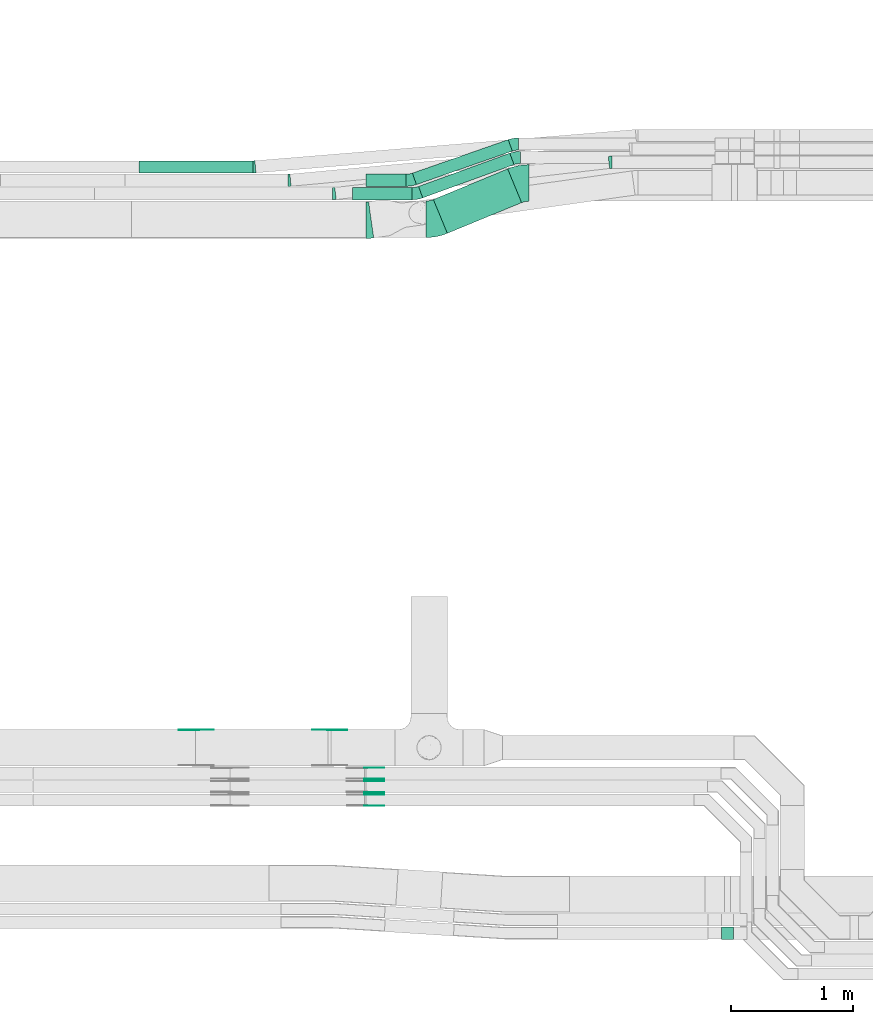
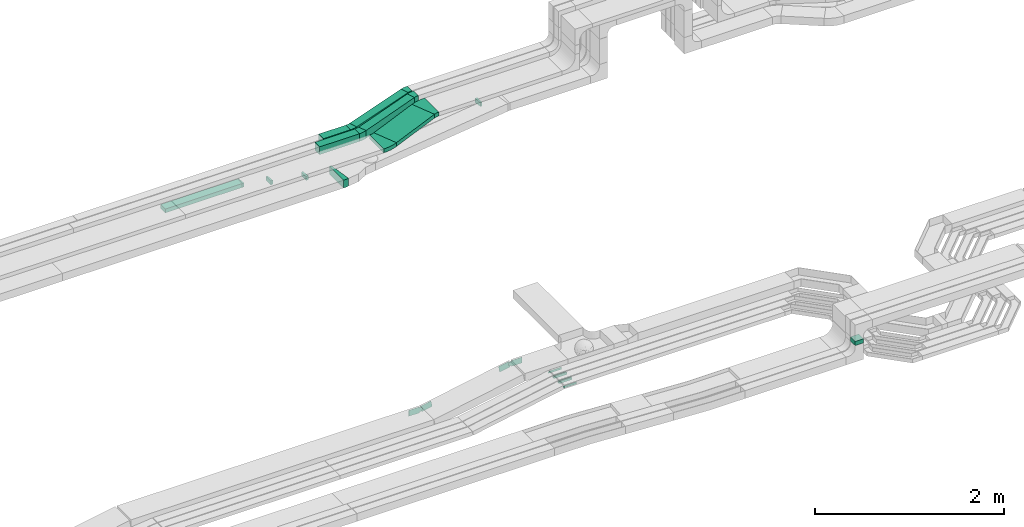
# One storey, part 13 of 33: 21 flow fittings, 7 flow segments.
"""IFC2X3 building model written with IfcOpenShell, lengths in millimetres."""

from ifc_helpers import new_model, entity, si_unit, converted_unit, derived_unit, direction, frame, frame_2d, origin, origin_2d_with_axis, place, context, subcontext, project, spatial, polyline, circle_curve, parameter, trimmed, segment, composite_curve, rectangle, outline, extrude, source, transform, mapped, material, type_object, type_shapes, element, save


model = new_model("IFC2X3")

# Units and contexts
model_context = context("Model", 3, precision=0.01, world=origin(), true_north=direction((6.12303176911189e-17, 1.0)))
body_context = subcontext(model_context, "Body", "Model", "MODEL_VIEW")
ifc_project = project(units=[si_unit("LENGTHUNIT", "METRE", prefix="MILLI"), si_unit("AREAUNIT", "SQUARE_METRE"), si_unit("VOLUMEUNIT", "CUBIC_METRE"), converted_unit("PLANEANGLEUNIT", "DEGREE", entity("IfcRatioMeasure", 0.0174532925199433), si_unit("PLANEANGLEUNIT", "RADIAN"), dimensions=[0, 0, 0, 0, 0, 0, 0]), si_unit("MASSUNIT", "GRAM", prefix="KILO"), derived_unit("MASSDENSITYUNIT", [(si_unit("MASSUNIT", "GRAM", prefix="KILO"), 1), (si_unit("LENGTHUNIT", "METRE"), -3)]), derived_unit("MOMENTOFINERTIAUNIT", [(si_unit("LENGTHUNIT", "METRE"), 4)]), si_unit("TIMEUNIT", "SECOND"), si_unit("FREQUENCYUNIT", "HERTZ"), si_unit("THERMODYNAMICTEMPERATUREUNIT", "DEGREE_CELSIUS"), derived_unit("THERMALTRANSMITTANCEUNIT", [(si_unit("MASSUNIT", "GRAM", prefix="KILO"), 1), (si_unit("THERMODYNAMICTEMPERATUREUNIT", "KELVIN"), -1), (si_unit("TIMEUNIT", "SECOND"), -3)]), derived_unit("VOLUMETRICFLOWRATEUNIT", [(si_unit("LENGTHUNIT", "METRE"), 3), (si_unit("TIMEUNIT", "SECOND"), -1)]), derived_unit("MASSFLOWRATEUNIT", [(si_unit("MASSUNIT", "GRAM", prefix="KILO"), 1), (si_unit("TIMEUNIT", "SECOND"), -1)]), derived_unit("ROTATIONALFREQUENCYUNIT", [(si_unit("TIMEUNIT", "SECOND"), -1)]), si_unit("ELECTRICCURRENTUNIT", "AMPERE"), si_unit("ELECTRICVOLTAGEUNIT", "VOLT"), si_unit("POWERUNIT", "WATT"), si_unit("FORCEUNIT", "NEWTON", prefix="KILO"), si_unit("ILLUMINANCEUNIT", "LUX"), si_unit("LUMINOUSFLUXUNIT", "LUMEN"), si_unit("LUMINOUSINTENSITYUNIT", "CANDELA"), derived_unit("USERDEFINED", [(si_unit("MASSUNIT", "GRAM", prefix="KILO"), -1), (si_unit("LENGTHUNIT", "METRE"), -2), (si_unit("TIMEUNIT", "SECOND"), 3), (si_unit("LUMINOUSFLUXUNIT", "LUMEN"), 1)]), derived_unit("LINEARVELOCITYUNIT", [(si_unit("LENGTHUNIT", "METRE"), 1), (si_unit("TIMEUNIT", "SECOND"), -1)]), si_unit("PRESSUREUNIT", "PASCAL"), derived_unit("USERDEFINED", [(si_unit("LENGTHUNIT", "METRE"), -2), (si_unit("MASSUNIT", "GRAM", prefix="KILO"), 1), (si_unit("TIMEUNIT", "SECOND"), -2)]), derived_unit("LINEARFORCEUNIT", [(si_unit("MASSUNIT", "GRAM", prefix="KILO"), 1), (si_unit("LENGTHUNIT", "METRE"), 1), (si_unit("TIMEUNIT", "SECOND"), -2), (si_unit("LENGTHUNIT", "METRE"), -1)]), derived_unit("PLANARFORCEUNIT", [(si_unit("MASSUNIT", "GRAM", prefix="KILO"), 1), (si_unit("LENGTHUNIT", "METRE"), 1), (si_unit("TIMEUNIT", "SECOND"), -2), (si_unit("LENGTHUNIT", "METRE"), -2)])], contexts=[model_context])

# Site, building, storey
site_placement = place(None, frame((0.0, -0.00077364408347762, 0.0)))
site = spatial("IfcSite", under=ifc_project, at=site_placement, CompositionType="ELEMENT")
building_placement = place(site_placement, origin())
building = spatial("IfcBuilding", under=site, at=building_placement, CompositionType="ELEMENT")
storey_placement = place(building_placement, frame((0.0, 0.0, 8100.0)))
storey = spatial("IfcBuildingStorey", under=building, at=storey_placement, CompositionType="ELEMENT", Elevation=8100.0)

# Flow segments
cable_carrier_segment_type = type_object("IfcCableCarrierSegmentType", PredefinedType="CABLETRAYSEGMENT")
flow_segment_1_placement = place(storey_placement, frame((27126.5045449638, 14216.6993529965, 2840.01712441882)))
element("IfcFlowSegment", 1, at=flow_segment_1_placement, inside=storey, type_object=cable_carrier_segment_type, context=body_context, shape_type="SweptSolid", body=[
    extrude(rectangle(XDim=659.52836889801, YDim=299.999999999997, at=frame_2d((8.24229573481716e-13, 2.01794136955868e-12), x_axis=(1.0, 0.0))), frame((362.049152556939, 264.468387444949, 0.0), z_axis=(0.0, 0.0, 1.0), x_axis=(-0.924356472691493, -0.381529961331139, 0.0)), (0.0, 0.0, 1.0), 50.0000000000016),
])
flow_segment_2_placement = place(storey_placement, frame((27004.8221282294, 14507.7317478892, 2840.0)))
element("IfcFlowSegment", 2, at=flow_segment_2_placement, inside=storey, type_object=cable_carrier_segment_type, context=body_context, shape_type="SweptSolid", body=[
    extrude(rectangle(XDim=797.077067377563, YDim=99.9999999999991, at=frame_2d((3.32534000335727e-12, -3.5278446830489e-12), x_axis=(1.0, 0.0))), frame((391.56891335788, 183.435992552252, 0.0), z_axis=(0.0, 0.0, 1.0), x_axis=(-0.939555537595458, -0.342396541708164, 0.0)), (0.0, 0.0, 1.0), 99.9999999999989),
])
flow_segment_3_placement = place(storey_placement, frame((26954.3095022686, 14616.5840674657, 2840.0)))
element("IfcFlowSegment", 3, at=flow_segment_3_placement, inside=storey, type_object=cable_carrier_segment_type, context=body_context, shape_type="SweptSolid", body=[
    extrude(rectangle(XDim=833.426581075166, YDim=100.000000000001, at=frame_2d((2.35900188272353e-12, 3.23296944770846e-13), x_axis=(1.0, 0.0))), frame((409.90070942409, 184.583672975688, 0.0), z_axis=(0.0, 0.0, 1.0), x_axis=(-0.944095363050818, -0.329672482118153, 0.0)), (0.0, 0.0, 1.0), 99.9999999999989),
])
flow_segment_4_placement = place(storey_placement, frame((24709.6133048514, 14712.2782357463, 2570.0)))
element("IfcFlowSegment", 4, at=flow_segment_4_placement, inside=storey, type_object=cable_carrier_segment_type, context=body_context, shape_type="SweptSolid", body=[
    extrude(rectangle(XDim=937.962058538578, YDim=99.9999999999989, at=frame_2d((0.0, 2.16715534406831e-12), x_axis=(1.0, 0.0))), frame((468.981029269289, 50.0, 0.0)), (0.0, 0.0, 1.0), 50.0000000000016),
])
flow_segment_5_placement = place(storey_placement, frame((26464.099792896, 14492.2782357463, 2840.0)))
element("IfcFlowSegment", 5, at=flow_segment_5_placement, inside=storey, type_object=cable_carrier_segment_type, context=body_context, shape_type="SweptSolid", body=[
    extrude(rectangle(XDim=487.423298539587, YDim=99.9999999999989, at=origin_2d_with_axis()), frame((243.711649269793, 50.0, 0.0)), (0.0, 0.0, 1.0), 99.9999999999989),
])
flow_segment_6_placement = place(storey_placement, frame((26574.099792896, 14602.2782357463, 2840.0)))
element("IfcFlowSegment", 6, at=flow_segment_6_placement, inside=storey, type_object=cable_carrier_segment_type, context=body_context, shape_type="SweptSolid", body=[
    extrude(rectangle(XDim=328.814741691739, YDim=99.9999999999989, at=origin_2d_with_axis()), frame((164.40737084587, 50.0, 0.0)), (0.0, 0.0, 1.0), 99.9999999999989),
])
flow_segment_7_placement = place(storey_placement, frame((29489.4603210585, 8422.4518205444, 2999.3193251973)))
element("IfcFlowSegment", 7, at=flow_segment_7_placement, inside=storey, type_object=cable_carrier_segment_type, context=body_context, shape_type="SweptSolid", body=[
    extrude(rectangle(XDim=100.000000000001, YDim=100.000000000003, at=frame_2d((1.08357767203415e-12, -4.33431068813661e-12), x_axis=(1.0, 0.0))), frame((50.0, 50.0, 0.0), z_axis=(0.0, 0.0, 1.0), x_axis=(0.0, 1.0, 0.0)), (0.0, 0.0, 1.0), 54.9788826680355),
])

# Flow fittings
ifc_material_1 = material()
cable_carrier_fitting_type_1 = type_object("IfcCableCarrierFittingType", Name="470_DKC_S5_Variable Angle Elbow 0-45:-", PredefinedType="NOTDEFINED", material=ifc_material_1)
shared_shape_1 = source(origin(), body_context, "Body", "SweptSolid", [
    extrude(outline(composite_curve([segment(polyline([(-12.2888732950033, -50.6676442286709), (-11.288873295002, -50.6676442286709)]), True, "CONTINUOUS"), segment(trimmed(circle_curve(frame_2d((-11.2888732950024, 199.332355771329), x_axis=(0.0, -1.0)), 250.0), [parameter(0.0)], [parameter(6.48278712085122)], True, "PARAMETER"), True, "CONTINUOUS"), segment(polyline([(16.9373063053102, -49.0690991059942), (17.9309121248195, -48.956194387593)]), True, "CONTINUOUS"), segment(polyline([(17.9309121248195, -48.956194387593), (6.64044028469449, 50.4043875633362)]), True, "CONTINUOUS"), segment(polyline([(6.64044028469449, 50.4043875633362), (5.64683446518516, 50.291482844935)]), True, "CONTINUOUS"), segment(trimmed(circle_curve(frame_2d((-11.2888732950024, 199.332355771329), x_axis=(0.0, -1.0)), 150.0), [parameter(0.0)], [parameter(6.48278712085122)], True, "PARAMETER"), False, "CONTINUOUS"), segment(polyline([(-11.288873295002, 49.3323557713289), (-12.2888732950033, 49.3323557713289)]), True, "CONTINUOUS"), segment(polyline([(-12.2888732950033, 49.3323557713289), (-12.2888732950033, -50.6676442286709)]), True, "CONTINUOUS")], self_intersect=False)), frame((-0.0378109769108159, 0.667644228662868, -25.0)), (0.0, 0.0, 1.0), 50.0000000000002),
])
type_shapes(cable_carrier_fitting_type_1, [shared_shape_1])
flow_fitting_1_placement = place(storey_placement, frame((28579.3619434365, 14800.0572451365, 2590.34290576127), z_axis=(0.0, 0.0, 1.0), x_axis=(-1.0, 0.0, 0.0)))
element("IfcFlowFitting", 8, at=flow_fitting_1_placement, inside=storey, type_object=cable_carrier_fitting_type_1, material=ifc_material_1, Name="470_DKC_S5_Variable Angle Elbow 0-45:-", ObjectType="470_DKC_S5_Variable Angle Elbow 0-45:-", context=body_context, shape_type="MappedRepresentation", body=[
    mapped(shared_shape_1, transform((0.0, 0.0, 0.0), scale=1.0)),
])
flow_fitting_2_placement = place(storey_placement, frame((26310.8055225511, 14542.2782357464, 2590.34290576127)))
element("IfcFlowFitting", 9, at=flow_fitting_2_placement, inside=storey, type_object=cable_carrier_fitting_type_1, material=ifc_material_1, Name="470_DKC_S5_Variable Angle Elbow 0-45:-", ObjectType="470_DKC_S5_Variable Angle Elbow 0-45:-", context=body_context, shape_type="MappedRepresentation", body=[
    mapped(shared_shape_1, transform((0.0, 0.0, 0.0), scale=1.0)),
])
cable_carrier_fitting_type_2 = type_object("IfcCableCarrierFittingType", Name="470_DKC_S5_Variable Angle Elbow 0-45:-", PredefinedType="NOTDEFINED", material=ifc_material_1)
shared_shape_2 = source(origin(), body_context, "Body", "SweptSolid", [
    extrude(outline(composite_curve([segment(polyline([(-10.155602411636, -50.4429955087325), (-9.15560241163469, -50.4429955087325)]), True, "CONTINUOUS"), segment(trimmed(circle_curve(frame_2d((-9.15560241163514, 199.557004491267), x_axis=(0.0, -1.0)), 250.0), [parameter(0.0)], [parameter(5.25373463552036)], True, "PARAMETER"), True, "CONTINUOUS"), segment(polyline([(13.7360292666842, -49.3927358160969), (14.7318282279136, -49.3011692893836)]), True, "CONTINUOUS"), segment(polyline([(14.7318282279136, -49.3011692893836), (5.575175556586, 50.278726833562)]), True, "CONTINUOUS"), segment(polyline([(5.57517555658601, 50.278726833562), (4.57937659535649, 50.1871603068488)]), True, "CONTINUOUS"), segment(trimmed(circle_curve(frame_2d((-9.15560241163514, 199.557004491267), x_axis=(0.0, -1.0)), 150.0), [parameter(0.0)], [parameter(5.25373463552036)], True, "PARAMETER"), False, "CONTINUOUS"), segment(polyline([(-9.15560241163469, 49.5570044912674), (-10.155602411636, 49.5570044912674)]), True, "CONTINUOUS"), segment(polyline([(-10.155602411636, 49.5570044912674), (-10.155602411636, -50.4429955087325)]), True, "CONTINUOUS")], self_intersect=False)), frame((-0.0203244719797119, 0.44299550872446, -25.0)), (0.0, 0.0, 1.0), 50.0000000000002),
])
type_shapes(cable_carrier_fitting_type_2, [shared_shape_2])
flow_fitting_3_placement = place(storey_placement, frame((25943.4125517949, 14652.2782357463, 2595.0)))
element("IfcFlowFitting", 10, at=flow_fitting_3_placement, inside=storey, type_object=cable_carrier_fitting_type_2, material=ifc_material_1, Name="470_DKC_S5_Variable Angle Elbow 0-45:-", ObjectType="470_DKC_S5_Variable Angle Elbow 0-45:-", context=body_context, shape_type="MappedRepresentation", body=[
    mapped(shared_shape_2, transform((0.0, 0.0, 0.0), scale=1.0)),
])
cable_carrier_fitting_type_3 = type_object("IfcCableCarrierFittingType", Name="470_DKC_S5_Variable Angle Elbow 0-45:-", PredefinedType="NOTDEFINED", material=ifc_material_1)
shared_shape_3 = source(origin(), body_context, "Body", "SweptSolid", [
    extrude(outline(composite_curve([segment(polyline([(-9.17792586537339, -50.3554689628789), (-8.17792586537208, -50.3554689628789)]), True, "CONTINUOUS"), segment(trimmed(circle_curve(frame_2d((-8.17792586537254, 199.644531037121), x_axis=(0.0, -1.0)), 250.0), [parameter(0.0)], [parameter(4.69132642007995)], True, "PARAMETER"), True, "CONTINUOUS"), segment(polyline([(12.2689826858983, -49.5179138270597), (13.2656324653548, -49.4361261928547)]), True, "CONTINUOUS"), segment(polyline([(13.2656324653548, -49.4361261928546), (5.08686904484686, 50.2288517528176)]), True, "CONTINUOUS"), segment(polyline([(5.08686904484686, 50.2288517528176), (4.09021926538994, 50.1470641186125)]), True, "CONTINUOUS"), segment(trimmed(circle_curve(frame_2d((-8.17792586537254, 199.644531037121), x_axis=(0.0, -1.0)), 150.0), [parameter(0.0)], [parameter(4.69132642007995)], True, "PARAMETER"), False, "CONTINUOUS"), segment(polyline([(-8.17792586537208, 49.644531037121), (-9.17792586537339, 49.644531037121)]), True, "CONTINUOUS"), segment(polyline([(-9.17792586537339, 49.644531037121), (-9.17792586537339, -50.3554689628789)]), True, "CONTINUOUS")], self_intersect=False)), frame((-0.0145608738130905, 0.355468962870826, -25.0)), (0.0, 0.0, 1.0), 50.0000000000002),
])
type_shapes(cable_carrier_fitting_type_3, [shared_shape_3])
flow_fitting_4_placement = place(storey_placement, frame((25656.7678501292, 14762.2782357463, 2595.0)))
element("IfcFlowFitting", 11, at=flow_fitting_4_placement, inside=storey, type_object=cable_carrier_fitting_type_3, material=ifc_material_1, Name="470_DKC_S5_Variable Angle Elbow 0-45:-", ObjectType="470_DKC_S5_Variable Angle Elbow 0-45:-", context=body_context, shape_type="MappedRepresentation", body=[
    mapped(shared_shape_3, transform((0.0, 0.0, 0.0), scale=1.0)),
])
cable_carrier_fitting_type_4 = type_object("IfcCableCarrierFittingType", Name="470_DKC_S5_Variable Angle Elbow 0-45:-", PredefinedType="NOTDEFINED", material=ifc_material_1)
shared_shape_4 = source(origin(), body_context, "Body", "SweptSolid", [
    extrude(outline(composite_curve([segment(polyline([(-58.2105833178417, -161.44191158661), (-57.2105833178401, -161.44191158661)]), True, "CONTINUOUS"), segment(trimmed(circle_curve(frame_2d((-57.2105833178485, 288.55808841339), x_axis=(0.0, -1.0)), 450.0), [parameter(0.0)], [parameter(22.4284842268306)], True, "PARAMETER"), True, "CONTINUOUS"), segment(polyline([(114.47789928117, -127.402324297779), (115.402255753862, -127.020794336448)]), True, "CONTINUOUS"), segment(polyline([(115.402255753862, -127.020794336448), (0.943267354516038, 150.286147470998)]), True, "CONTINUOUS"), segment(polyline([(0.943267354516038, 150.286147470998), (0.0189108818244559, 149.904617509667)]), True, "CONTINUOUS"), segment(trimmed(circle_curve(frame_2d((-57.2105833178485, 288.55808841339), x_axis=(0.0, -1.0)), 150.0), [parameter(0.0)], [parameter(22.4284842268306)], True, "PARAMETER"), False, "CONTINUOUS"), segment(polyline([(-57.2105833178452, 138.55808841339), (-58.2105833178468, 138.55808841339)]), True, "CONTINUOUS"), segment(polyline([(-58.2105833178468, 138.55808841339), (-58.2105833178417, -161.44191158661)]), True, "CONTINUOUS")], self_intersect=False)), frame((-2.26851529179941, 11.4419115866006, -25.0)), (0.0, 0.0, 1.0), 49.9999999999992),
])
type_shapes(cable_carrier_fitting_type_4, [shared_shape_4])
flow_fitting_5_placement = place(storey_placement, frame((27849.2776021404, 14630.0572451366, 2865.01712441882), z_axis=(0.0, 0.0, 1.0), x_axis=(-1.0, 0.0, 0.0)))
element("IfcFlowFitting", 12, at=flow_fitting_5_placement, inside=storey, type_object=cable_carrier_fitting_type_4, material=ifc_material_1, Name="470_DKC_S5_Variable Angle Elbow 0-45:-", ObjectType="470_DKC_S5_Variable Angle Elbow 0-45:-", context=body_context, shape_type="MappedRepresentation", body=[
    mapped(shared_shape_4, transform((0.0, 0.0, 0.0), scale=1.0)),
])
flow_fitting_6_placement = place(storey_placement, frame((27127.8297929011, 14332.2782357464, 2865.01712441882)))
element("IfcFlowFitting", 13, at=flow_fitting_6_placement, inside=storey, type_object=cable_carrier_fitting_type_4, material=ifc_material_1, Name="470_DKC_S5_Variable Angle Elbow 0-45:-", ObjectType="470_DKC_S5_Variable Angle Elbow 0-45:-", context=body_context, shape_type="MappedRepresentation", body=[
    mapped(shared_shape_4, transform((0.0, 0.0, 0.0), scale=1.0)),
])
cable_carrier_fitting_type_5 = type_object("IfcCableCarrierFittingType", Name="470_DKC_S5_Variable Angle Elbow 0-45:-", PredefinedType="NOTDEFINED", material=ifc_material_1)
shared_shape_5 = source(origin(), body_context, "Body", "SweptSolid", [
    extrude(outline(composite_curve([segment(polyline([(-35.2245430552161, -56.1300453758817), (-34.2245430552148, -56.1300453758817)]), True, "CONTINUOUS"), segment(trimmed(circle_curve(frame_2d((-34.2245430552174, 193.869954624118), x_axis=(0.0, -1.0)), 250.0), [parameter(0.0)], [parameter(20.0229517728653)], True, "PARAMETER"), True, "CONTINUOUS"), segment(polyline([(51.3745923718267, -41.018929774745), (52.3141479094222, -40.6765332330368)]), True, "CONTINUOUS"), segment(polyline([(52.3141479094222, -40.6765332330368), (18.0744937386045, 53.2790205265084)]), True, "CONTINUOUS"), segment(polyline([(18.0744937386045, 53.2790205265084), (17.1349382010091, 52.9366239848002)]), True, "CONTINUOUS"), segment(trimmed(circle_curve(frame_2d((-34.2245430552174, 193.869954624118), x_axis=(0.0, -1.0)), 150.0), [parameter(0.0)], [parameter(20.0229517728653)], True, "PARAMETER"), False, "CONTINUOUS"), segment(polyline([(-34.2245430552156, 43.8699546241182), (-35.224543055217, 43.8699546241182)]), True, "CONTINUOUS"), segment(polyline([(-35.224543055217, 43.8699546241182), (-35.2245430552161, -56.1300453758817)]), True, "CONTINUOUS")], self_intersect=False)), frame((-1.0821584102712, 6.13004537587337, -50.0)), (0.0, 0.0, 1.0), 100.0),
])
type_shapes(cable_carrier_fitting_type_5, [shared_shape_5])
flow_fitting_7_placement = place(storey_placement, frame((27804.9522902735, 14840.0572451365, 2890.0), z_axis=(0.0, 0.0, 1.0), x_axis=(-1.0, 0.0, 0.0)))
element("IfcFlowFitting", 14, at=flow_fitting_7_placement, inside=storey, type_object=cable_carrier_fitting_type_5, material=ifc_material_1, Name="470_DKC_S5_Variable Angle Elbow 0-45:-", ObjectType="470_DKC_S5_Variable Angle Elbow 0-45:-", context=body_context, shape_type="MappedRepresentation", body=[
    mapped(shared_shape_5, transform((0.0, 0.0, 0.0), scale=1.0)),
])
flow_fitting_8_placement = place(storey_placement, frame((26987.8297929011, 14542.2782357464, 2890.0)))
element("IfcFlowFitting", 15, at=flow_fitting_8_placement, inside=storey, type_object=cable_carrier_fitting_type_5, material=ifc_material_1, Name="470_DKC_S5_Variable Angle Elbow 0-45:-", ObjectType="470_DKC_S5_Variable Angle Elbow 0-45:-", context=body_context, shape_type="MappedRepresentation", body=[
    mapped(shared_shape_5, transform((0.0, 0.0, 0.0), scale=1.0)),
])
cable_carrier_fitting_type_6 = type_object("IfcCableCarrierFittingType", Name="470_DKC_S5_Variable Angle Elbow 0-45:-", PredefinedType="NOTDEFINED", material=ifc_material_1)
shared_shape_6 = source(origin(), body_context, "Body", "SweptSolid", [
    extrude(outline(composite_curve([segment(polyline([(-33.9532720525793, -55.6728818154483), (-32.953272052578, -55.6728818154483)]), True, "CONTINUOUS"), segment(trimmed(circle_curve(frame_2d((-32.9532720525806, 194.327118184551), x_axis=(0.0, -1.0)), 250.0), [parameter(0.0)], [parameter(19.2488977013697)], True, "PARAMETER"), True, "CONTINUOUS"), segment(polyline([(49.4648484769619, -41.6967225781513), (50.4089438400126, -41.3670500960332)]), True, "CONTINUOUS"), segment(polyline([(50.4089438400126, -41.3670500960332), (17.4416956281959, 53.042486209048)]), True, "CONTINUOUS"), segment(polyline([(17.4416956281959, 53.042486209048), (16.4976002651449, 52.7128137269298)]), True, "CONTINUOUS"), segment(trimmed(circle_curve(frame_2d((-32.9532720525806, 194.327118184551), x_axis=(0.0, -1.0)), 150.0), [parameter(0.0)], [parameter(19.2488977013697)], True, "PARAMETER"), False, "CONTINUOUS"), segment(polyline([(-32.9532720525789, 44.3271181845516), (-33.9532720525802, 44.3271181845516)]), True, "CONTINUOUS"), segment(polyline([(-33.9532720525802, 44.3271181845516), (-33.9532720525793, -55.6728818154483)]), True, "CONTINUOUS")], self_intersect=False)), frame((-0.96198626075004, 5.67288181543997, -50.0)), (0.0, 0.0, 1.0), 100.0),
])
type_shapes(cable_carrier_fitting_type_6, [shared_shape_6])
flow_fitting_9_placement = place(storey_placement, frame((27790.5906304842, 14950.0572451365, 2890.0), z_axis=(0.0, 0.0, 1.0), x_axis=(-1.0, 0.0, 0.0)))
element("IfcFlowFitting", 16, at=flow_fitting_9_placement, inside=storey, type_object=cable_carrier_fitting_type_6, material=ifc_material_1, Name="470_DKC_S5_Variable Angle Elbow 0-45:-", ObjectType="470_DKC_S5_Variable Angle Elbow 0-45:-", context=body_context, shape_type="MappedRepresentation", body=[
    mapped(shared_shape_6, transform((0.0, 0.0, 0.0), scale=1.0)),
])
flow_fitting_10_placement = place(storey_placement, frame((26937.8297929011, 14652.2782357463, 2890.0)))
element("IfcFlowFitting", 17, at=flow_fitting_10_placement, inside=storey, type_object=cable_carrier_fitting_type_6, material=ifc_material_1, Name="470_DKC_S5_Variable Angle Elbow 0-45:-", ObjectType="470_DKC_S5_Variable Angle Elbow 0-45:-", context=body_context, shape_type="MappedRepresentation", body=[
    mapped(shared_shape_6, transform((0.0, 0.0, 0.0), scale=1.0)),
])
cable_carrier_fitting_type_7 = type_object("IfcCableCarrierFittingType", Name="470_DKC_S5_Variable Angle Elbow 0-45:-", PredefinedType="NOTDEFINED", material=ifc_material_1)
shared_shape_7 = source(origin(), body_context, "Body", "SweptSolid", [
    extrude(outline(composite_curve([segment(polyline([(-21.848259542613, -151.490990359937), (-20.8482595426114, -151.490990359937)]), True, "CONTINUOUS"), segment(trimmed(circle_curve(frame_2d((-20.8482595426198, 298.509009640063), x_axis=(0.0, -1.0)), 450.0), [parameter(0.0)], [parameter(7.99024953505022)], True, "PARAMETER"), True, "CONTINUOUS"), segment(polyline([(41.7038002813094, -147.122272713166), (42.6940920198722, -146.98326813578)]), True, "CONTINUOUS"), segment(polyline([(42.6940920198722, -146.98326813578), (0.99271880391937, 150.10425343304)]), True, "CONTINUOUS"), segment(polyline([(0.99271880391937, 150.10425343304), (0.00242706535666982, 149.965248855653)]), True, "CONTINUOUS"), segment(trimmed(circle_curve(frame_2d((-20.8482595426198, 298.509009640063), x_axis=(0.0, -1.0)), 150.0), [parameter(0.0)], [parameter(7.99024953505022)], True, "PARAMETER"), False, "CONTINUOUS"), segment(polyline([(-20.8482595426165, 148.509009640063), (-21.8482595426181, 148.509009640063)]), True, "CONTINUOUS"), segment(polyline([(-21.8482595426181, 148.509009640063), (-21.848259542613, -151.490990359937)]), True, "CONTINUOUS")], self_intersect=False)), frame((-0.10413271624188, 1.49099035992839, -50.0)), (0.0, 0.0, 1.0), 99.9999999999997),
])
type_shapes(cable_carrier_fitting_type_7, [shared_shape_7])
flow_fitting_11_placement = place(storey_placement, frame((26594.0461453101, 14324.4992263561, 2615.0)))
element("IfcFlowFitting", 18, at=flow_fitting_11_placement, inside=storey, type_object=cable_carrier_fitting_type_7, material=ifc_material_1, Name="470_DKC_S5_Variable Angle Elbow 0-45:-", ObjectType="470_DKC_S5_Variable Angle Elbow 0-45:-", context=body_context, shape_type="MappedRepresentation", body=[
    mapped(shared_shape_7, transform((0.0, 0.0, 0.0), scale=1.0)),
])
ifc_material_2 = material(Name="G")
cable_carrier_fitting_type_8 = type_object("IfcCableCarrierFittingType", PredefinedType="NOTDEFINED", material=ifc_material_2)
shared_shape_8 = source(origin(), body_context, "Body", "SweptSolid", [
    extrude(outline(composite_curve([segment(trimmed(circle_curve(frame_2d((-44.5901162790698, 0.0), x_axis=(1.0, 0.0)), 12.5), [parameter(90.0000000000007)], [parameter(270.0)], True, "PARAMETER"), True, "CONTINUOUS"), segment(polyline([(-44.5901162790697, -12.5), (-33.0901162790698, -12.5)]), True, "CONTINUOUS"), segment(polyline([(-33.0901162790698, -12.5), (-31.2296511627907, -14.5)]), True, "CONTINUOUS"), segment(polyline([(-31.2296511627907, -14.5), (108.90988372093, -14.5)]), True, "CONTINUOUS"), segment(polyline([(108.90988372093, -14.5), (108.90988372093, 14.5)]), True, "CONTINUOUS"), segment(polyline([(108.90988372093, 14.5), (-31.2296511627907, 14.5)]), True, "CONTINUOUS"), segment(polyline([(-31.2296511627907, 14.5), (-33.0901162790698, 12.5)]), True, "CONTINUOUS"), segment(polyline([(-33.0901162790698, 12.5), (-44.5901162790699, 12.5)]), True, "CONTINUOUS")], self_intersect=False)), frame((44.5901162790698, 0.0, 0.0), z_axis=(0.0, 0.0, -1.0), x_axis=(1.0, 0.0, 0.0)), (0.0, 0.0, -1.0), 2.0),
])
type_shapes(cable_carrier_fitting_type_8, [shared_shape_8])
for number, where, z_axis, x_axis in (
    (19, (26571.188240847, 9610.93519662157, 2825.0), (0.0, 1.0, 0.0), (1.0, 0.0, 0.0)),
    (20, (26570.5547361058, 9720.93519662161, 2825.0), (0.0, 1.0, 0.0), (1.0, 0.0, 0.0)),
    (21, (26570.7128245376, 9830.45855347689, 2825.0), (0.0, 1.0, 0.0), (1.0, 0.0, 0.0)),
):
    element("IfcFlowFitting", number, at=place(storey_placement, frame(where, z_axis=z_axis, x_axis=x_axis)), inside=storey, type_object=cable_carrier_fitting_type_8, material=ifc_material_2, context=body_context, shape_type="MappedRepresentation", body=[
        mapped(shared_shape_8, transform((0.0, 0.0, 0.0), scale=1.0)),
    ])
cable_carrier_fitting_type_9 = type_object("IfcCableCarrierFittingType", PredefinedType="NOTDEFINED", material=ifc_material_2)
shared_shape_9 = source(origin(), body_context, "Body", "SweptSolid", [
    extrude(outline(composite_curve([segment(trimmed(circle_curve(frame_2d((-44.5901162790697, 0.0), x_axis=(1.0, 0.0)), 12.5), [parameter(90.0000000000007)], [parameter(270.0)], True, "PARAMETER"), True, "CONTINUOUS"), segment(polyline([(-44.5901162790697, -12.5), (-33.0901162790697, -12.5)]), True, "CONTINUOUS"), segment(polyline([(-33.0901162790697, -12.5), (-31.2296511627907, -14.5)]), True, "CONTINUOUS"), segment(polyline([(-31.2296511627907, -14.5), (108.90988372093, -14.5)]), True, "CONTINUOUS"), segment(polyline([(108.90988372093, -14.5), (108.90988372093, 14.5)]), True, "CONTINUOUS"), segment(polyline([(108.90988372093, 14.5), (-31.2296511627907, 14.5)]), True, "CONTINUOUS"), segment(polyline([(-31.2296511627907, 14.5), (-33.0901162790698, 12.5)]), True, "CONTINUOUS"), segment(polyline([(-33.0901162790698, 12.5), (-44.5901162790699, 12.5)]), True, "CONTINUOUS")], self_intersect=False)), frame((44.5901162790697, 0.0, 0.0)), (0.0, 0.0, 1.0), 2.0),
])
type_shapes(cable_carrier_fitting_type_9, [shared_shape_9])
for number, where, z_axis, x_axis in (
    (22, (26571.188240847, 9520.01519660125, 2825.0), (0.0, -1.0, 0.0), (1.0, 0.0, 0.0)),
    (23, (26570.5547361058, 9630.01519660129, 2825.0), (0.0, -1.0, 0.0), (1.0, 0.0, 0.0)),
    (24, (26570.7128245376, 9739.53855345658, 2825.0), (0.0, -1.0, 0.0), (1.0, 0.0, 0.0)),
):
    element("IfcFlowFitting", number, at=place(storey_placement, frame(where, z_axis=z_axis, x_axis=x_axis)), inside=storey, type_object=cable_carrier_fitting_type_9, material=ifc_material_2, context=body_context, shape_type="MappedRepresentation", body=[
        mapped(shared_shape_9, transform((0.0, 0.0, 0.0), scale=1.0)),
    ])
cable_carrier_fitting_type_10 = type_object("IfcCableCarrierFittingType", PredefinedType="NOTDEFINED", material=ifc_material_2)
shared_shape_10 = source(origin(), body_context, "Body", "SweptSolid", [
    extrude(outline(composite_curve([segment(trimmed(circle_curve(frame_2d((-41.4651162790697, 0.0), x_axis=(1.0, 0.0)), 25.0), [parameter(90.0000000000007)], [parameter(270.0)], True, "PARAMETER"), True, "CONTINUOUS"), segment(polyline([(-41.4651162790697, -25.0), (-29.9651162790697, -25.0)]), True, "CONTINUOUS"), segment(polyline([(-29.9651162790697, -25.0), (-28.1046511627907, -38.5)]), True, "CONTINUOUS"), segment(polyline([(-28.1046511627907, -38.5), (99.5348837209303, -38.5)]), True, "CONTINUOUS"), segment(polyline([(99.5348837209303, -38.5), (99.5348837209303, 38.5)]), True, "CONTINUOUS"), segment(polyline([(99.5348837209303, 38.5), (-28.1046511627907, 38.5)]), True, "CONTINUOUS"), segment(polyline([(-28.1046511627907, 38.5), (-29.9651162790697, 25.0)]), True, "CONTINUOUS"), segment(polyline([(-29.9651162790697, 25.0), (-41.46511627907, 25.0)]), True, "CONTINUOUS")], self_intersect=False)), frame((41.4651162790697, 0.0, 0.0)), (0.0, 0.0, 1.0), 2.0),
])
type_shapes(cable_carrier_fitting_type_10, [shared_shape_10])
for number, where, z_axis, x_axis in (
    (25, (25178.5258658326, 10140.458553477, 2645.01712441877), (0.0, 1.0, 0.0), (0.983076107251628, 0.0, 0.183197618300528)),
    (26, (26278.5061453203, 10140.458553477, 2850.0), (0.0, 1.0, 0.0), (-0.983076107251628, 0.0, -0.183197618300528)),
):
    element("IfcFlowFitting", number, at=place(storey_placement, frame(where, z_axis=z_axis, x_axis=x_axis)), inside=storey, type_object=cable_carrier_fitting_type_10, material=ifc_material_2, context=body_context, shape_type="MappedRepresentation", body=[
        mapped(shared_shape_10, transform((0.0, 0.0, 0.0), scale=1.0)),
    ])
cable_carrier_fitting_type_11 = type_object("IfcCableCarrierFittingType", PredefinedType="NOTDEFINED", material=ifc_material_2)
shared_shape_11 = source(origin(), body_context, "Body", "SweptSolid", [
    extrude(outline(composite_curve([segment(trimmed(circle_curve(frame_2d((-41.4651162790697, 0.0), x_axis=(1.0, 0.0)), 25.0), [parameter(90.0000000000007)], [parameter(270.0)], True, "PARAMETER"), True, "CONTINUOUS"), segment(polyline([(-41.4651162790697, -25.0), (-29.9651162790697, -25.0)]), True, "CONTINUOUS"), segment(polyline([(-29.9651162790697, -25.0), (-28.1046511627907, -38.5)]), True, "CONTINUOUS"), segment(polyline([(-28.1046511627907, -38.5), (99.5348837209303, -38.5)]), True, "CONTINUOUS"), segment(polyline([(99.5348837209303, -38.5), (99.5348837209303, 38.5)]), True, "CONTINUOUS"), segment(polyline([(99.5348837209303, 38.5), (-28.1046511627907, 38.5)]), True, "CONTINUOUS"), segment(polyline([(-28.1046511627907, 38.5), (-29.9651162790697, 25.0)]), True, "CONTINUOUS"), segment(polyline([(-29.9651162790697, 25.0), (-41.46511627907, 25.0)]), True, "CONTINUOUS")], self_intersect=False)), frame((41.4651162790697, 0.0, 0.0), z_axis=(0.0, 0.0, -1.0), x_axis=(1.0, 0.0, 0.0)), (0.0, 0.0, -1.0), 2.0),
])
type_shapes(cable_carrier_fitting_type_11, [shared_shape_11])
for number, where, z_axis, x_axis in (
    (27, (25178.5258658326, 10138.458553477, 2645.01712441878), (0.0, 1.0, 0.0), (-1.0, 0.0, 0.0)),
    (28, (26278.5061453203, 10138.458553477, 2850.0), (0.0, 1.0, 0.0), (1.0, 0.0, 0.0)),
):
    element("IfcFlowFitting", number, at=place(storey_placement, frame(where, z_axis=z_axis, x_axis=x_axis)), inside=storey, type_object=cable_carrier_fitting_type_11, material=ifc_material_2, context=body_context, shape_type="MappedRepresentation", body=[
        mapped(shared_shape_11, transform((0.0, 0.0, 0.0), scale=1.0)),
    ])

save(model, "model.ifc")
